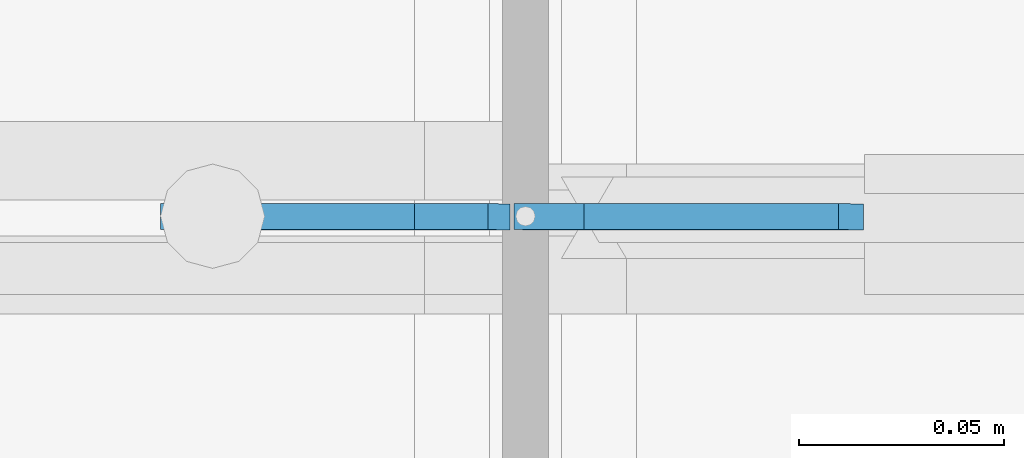
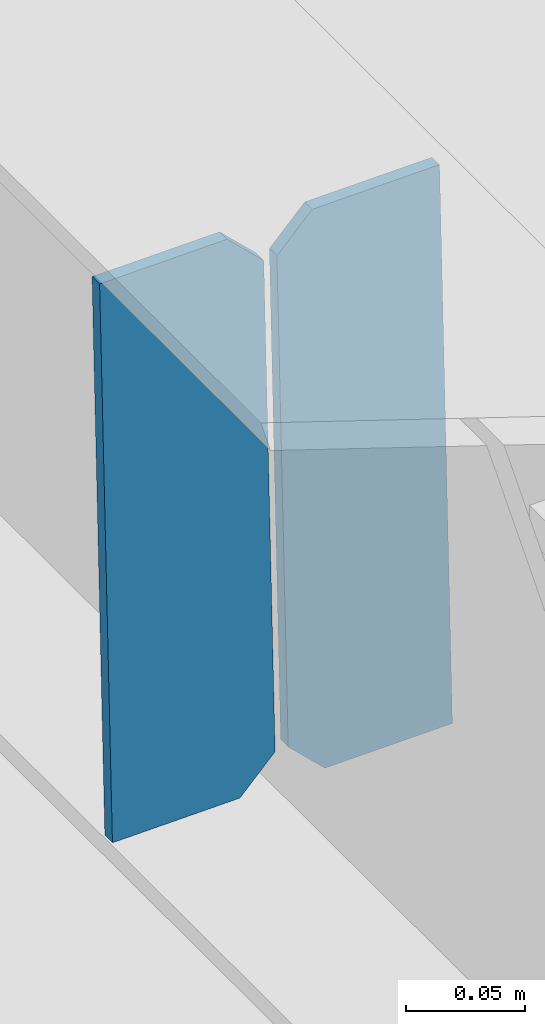
# One storey, part 3460 of 3843: 2 plates, 1 element without a shape of its own.
"""IFC2X3 building model written with IfcOpenShell, lengths in millimetres."""

from ifc_helpers import new_model, si_unit, frame, origin_with_axes, place, context, subcontext, project, spatial, faceted_brep, material, type_object, element, aggregate, save


model = new_model("IFC2X3")

# Units and contexts
model_context = context("Model", 3, precision=1e-05, world=origin_with_axes())
body_context = subcontext(model_context, "Body", "Model", "MODEL_VIEW")
ifc_project = project(units=[si_unit("LENGTHUNIT", "METRE", prefix="MILLI"), si_unit("AREAUNIT", "SQUARE_METRE"), si_unit("VOLUMEUNIT", "CUBIC_METRE"), si_unit("MASSUNIT", "GRAM", prefix="KILO"), si_unit("TIMEUNIT", "SECOND"), si_unit("PLANEANGLEUNIT", "RADIAN"), si_unit("SOLIDANGLEUNIT", "STERADIAN"), si_unit("THERMODYNAMICTEMPERATUREUNIT", "DEGREE_CELSIUS"), si_unit("LUMINOUSINTENSITYUNIT", "LUMEN")], contexts=[model_context])

# Site, building, storey
site_placement = place(None, origin_with_axes())
site = spatial("IfcSite", under=ifc_project, at=site_placement, CompositionType="ELEMENT")
building_placement = place(site_placement, origin_with_axes())
building = spatial("IfcBuilding", under=site, at=building_placement, Name="Undefined", CompositionType="ELEMENT")
storey_placement = place(building_placement, origin_with_axes())
storey = spatial("IfcBuildingStorey", under=building, at=storey_placement, Name="Undefined", CompositionType="ELEMENT", Elevation=0.0)

# Assembly, plates
assembly_placement = place(storey_placement, origin_with_axes())
assembly = element("IfcElementAssembly", 1, at=assembly_placement, inside=storey, Name="BEAM", AssemblyPlace="NOTDEFINED", PredefinedType="RIGID_FRAME")
ifc_material = material(Name="STEEL/A572-50")
plate_type = type_object("IfcPlateType", PredefinedType="NOTDEFINED")
plate_1_placement = place(assembly_placement, frame((49078.8964783425, 92214.4606235557, 45694.4251163554), z_axis=(-0.0211520978682966, 0.000677816999712377, 0.999776039580808), x_axis=(-0.999776269350183, -1.43399999262055e-05, -0.021152093007418)))
plate_1 = element("IfcPlate", 2, at=plate_1_placement, type_object=plate_type, material=ifc_material, Name="STIFFENER", context=body_context, shape_type="Brep", body=[
    faceted_brep([(0.0, -3.17499999999927, 0.0), (6.83940015733242e-10, -3.17499999996653, 288.924999998613), (6.54836185276508e-10, 3.17500000001746, 288.924999998591), (0.0, 3.17499999999927, 0.0), (61.9125003828667, -3.17499999997744, 288.924999998599), (61.9125003828522, 3.17500000002838, 288.924999998584), (79.3750000013097, -3.17499999997744, 271.462500380039), (79.375000001266, 3.17500000002838, 271.462500380017), (79.375000000713, -3.17499999999927, 17.4624996185448), (79.3750000006694, 3.17500000000291, 17.462499618523), (61.9125003821828, -3.17499999999563, -1.45519152283669e-11), (61.9125003821682, 3.17500000000655, -2.91038304567337e-11)], [[[0, 1, 2, 3]], [[1, 4, 5, 2]], [[4, 6, 7, 5]], [[6, 8, 9, 7]], [[8, 10, 11, 9]], [[10, 0, 3, 11]], [[5, 7, 9, 11, 3, 2]], [[10, 8, 6, 4, 1, 0]]]),
])
plate_2_placement = place(assembly_placement, frame((48993.1906576528, 92214.4593942197, 45692.6118531715), z_axis=(-0.0211520978682966, 0.000677816999712377, 0.999776039580808), x_axis=(-0.999776269350183, -1.43399999262055e-05, -0.021152093007418)))
plate_2 = element("IfcPlate", 3, at=plate_2_placement, type_object=plate_type, material=ifc_material, Name="STIFFENER", context=body_context, shape_type="Brep", body=[
    faceted_brep([(5.82076609134674e-11, -3.17499999999927, 17.4624996185667), (6.25732354819775e-10, -3.17499999997744, 271.462500380054), (5.82076609134674e-10, 3.17500000002474, 271.462500380039), (0.0, 3.17500000000655, 17.4624996185521), (17.462499619156, -3.17499999997744, 288.924999998606), (17.4624996191269, 3.17500000002474, 288.924999998591), (79.3750000013242, -3.17500000025029, 288.924999998591), (79.3750000013097, 3.1749999997337, 288.92499999857), (79.3750000006548, -3.17500000026484, -2.18278728425503e-11), (79.3750000006403, 3.17499999969732, -2.91038304567337e-11), (17.4624996184866, -3.17500000000291, 7.27595761418343e-12), (17.462499618443, 3.17500000000291, -7.27595761418343e-12)], [[[0, 1, 2, 3]], [[1, 4, 5, 2]], [[4, 6, 7, 5]], [[6, 8, 9, 7]], [[8, 10, 11, 9]], [[10, 0, 3, 11]], [[5, 7, 9, 11, 3, 2]], [[10, 8, 6, 4, 1, 0]]]),
])
aggregate(assembly, [plate_1, plate_2])

save(model, "model.ifc")
